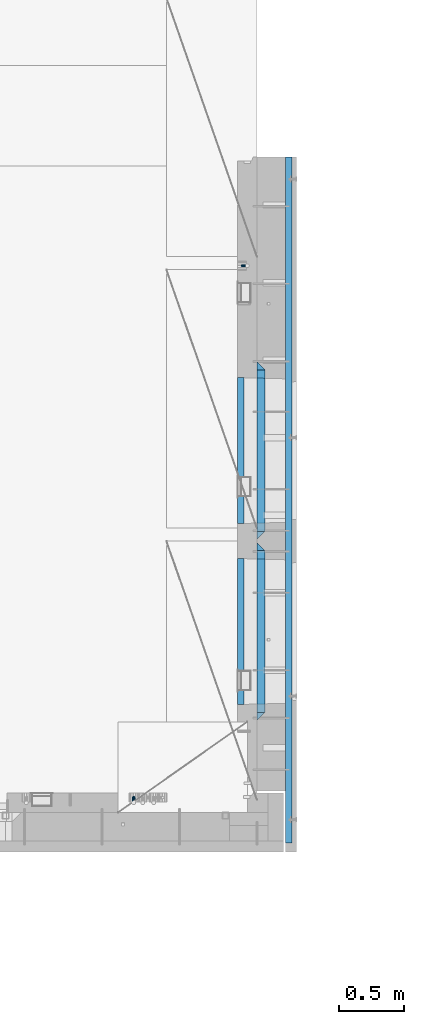
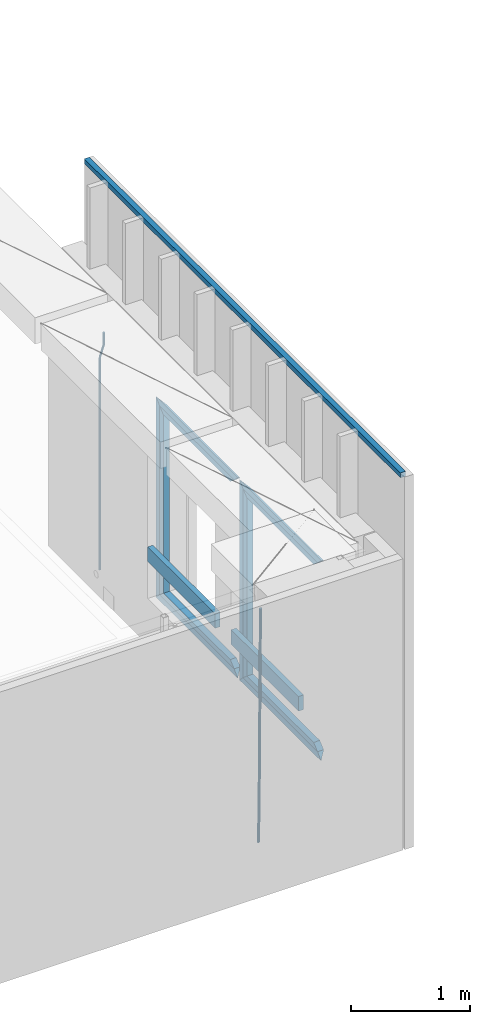
# One storey, part 112 of 309: 17 beams, 2 elements without a shape of their own.
"""IFC2X3 building model written with IfcOpenShell, lengths in millimetres."""

from ifc_helpers import new_model, si_unit, frame, origin_with_axes, place, context, subcontext, project, spatial, faceted_brep, material, type_object, element, aggregate, save


model = new_model("IFC2X3")

# Units and contexts
model_context = context("Model", 3, precision=1e-05, world=origin_with_axes())
body_context = subcontext(model_context, "Body", "Model", "MODEL_VIEW")
ifc_project = project(units=[si_unit("LENGTHUNIT", "METRE", prefix="MILLI"), si_unit("AREAUNIT", "SQUARE_METRE"), si_unit("VOLUMEUNIT", "CUBIC_METRE"), si_unit("MASSUNIT", "GRAM", prefix="KILO"), si_unit("TIMEUNIT", "SECOND"), si_unit("PLANEANGLEUNIT", "RADIAN"), si_unit("SOLIDANGLEUNIT", "STERADIAN"), si_unit("THERMODYNAMICTEMPERATUREUNIT", "DEGREE_CELSIUS"), si_unit("LUMINOUSINTENSITYUNIT", "LUMEN")], contexts=[model_context])

# Site, building, storey
site_placement = place(None, origin_with_axes())
site = spatial("IfcSite", under=ifc_project, at=site_placement, CompositionType="ELEMENT")
building_placement = place(site_placement, origin_with_axes())
building = spatial("IfcBuilding", under=site, at=building_placement, CompositionType="ELEMENT")
storey_placement = place(building_placement, origin_with_axes())
storey = spatial("IfcBuildingStorey", under=building, at=storey_placement, Name="7", CompositionType="ELEMENT", Elevation=0.0)

# Assembly, beam
assembly_1_placement = place(storey_placement, origin_with_axes())
assembly_1 = element("IfcElementAssembly", 1, at=assembly_1_placement, inside=storey, AssemblyPlace="NOTDEFINED", PredefinedType="REINFORCEMENT_UNIT")
ifc_material_1 = material()
beam_type_1 = type_object("IfcBeamType", Name="D20", PredefinedType="NOTDEFINED")
beam_1_placement = place(assembly_1_placement, frame((34985.0, 12080.0002860939, 102407.5), z_axis=(-0.999999913638316, 0.000415599999849952, 0.0), x_axis=(0.0, 0.0, -1.0)))
beam_1 = element("IfcBeam", 2, at=beam_1_placement, type_object=beam_type_1, material=ifc_material_1, Name="JM20", ObjectType="D20", context=body_context, shape_type="Brep", body=[
    faceted_brep([(0.0, -10.0, 0.0), (-4.19531716033816e-08, -7.07106781186667, -7.07106781187031), (113.248091332178, -7.0710684840451, -7.0710678117357), (113.248091314759, -10.0000006713562, -2.51020537689328e-10), (0.0, 0.0, -10.0), (113.248091374131, -6.72178430249915e-07, -9.99999999986903), (4.196772351861e-08, 7.07106781186303, -7.07106781186667), (113.248091416113, 7.07106713968824, -7.07106781173934), (0.0, 10.0, 0.0), (113.248091433488, 9.99999932782521, 1.30967237055302e-10), (4.196772351861e-08, 7.07106781185939, 7.07106781185939), (113.248091416113, 7.0710671396846, 7.071067811994), (0.0, 0.0, 10.0), (113.248091374131, -6.72174792271107e-07, 10.0000000001273), (-4.19531716033816e-08, -7.07106781187031, 7.07106781185939), (113.248091332178, -7.0710684840451, 7.071067811994), (130.699843527167, -7.06993249763036, -4.33745683788584), (128.538066582521, -9.99900540317321, 2.39499413731755), (131.594536475241, 0.00119355250353692, -7.12624594330919), (130.698046432328, 7.07220300913468, -4.33773834422391), (128.535525107087, 10.0009944322555, 2.39459602660281), (126.373748162892, 7.07192152754578, 9.1270470011732), (125.479055214906, 0.000795477419160306, 11.9158361066184), (126.37554525779, -7.07021397921199, 9.12732850753673), (240.336258550378, -7.05529970173666, 30.8729495437874), (238.174481606227, -9.98437260450009, 37.6054005176375), (241.230951498423, 0.0158263482953771, 28.0841604381058), (240.334461455612, 7.0868358050102, 30.8726680369582), (238.171940130502, 10.0156272283348, 37.6050024077231), (236.010163186409, 7.08655432384694, 44.3374533824244), (235.115470238379, 0.0154282738185429, 47.1262424881097), (236.011960281176, -7.05558118289991, 44.3377348892536), (253.461915329972, -7.05444528127919, 32.9289287376414), (253.46191532613, -9.98337746617108, 39.9999965521893), (253.461915339081, 0.0166225284556276, 29.9999965443676), (253.461915348205, 7.08769034247234, 32.9289287273205), (253.461915352003, 10.0166225357716, 39.9999965370152), (253.461915348293, 7.08769035281148, 47.0710643509774), (253.461915339183, 0.0166225430875784, 49.999996544273), (253.46191533003, -7.05444527093641, 47.0710643613093), (2417.50000002384, -7.0544364694706, 32.9289287374122), (2417.5000000337, -9.98336865393321, 39.9999965507959), (2417.49999999997, 0.0166313408753922, 29.9999965456082), (2417.49999997609, 7.08769915426274, 32.9289287300708), (2417.4999999662, 10.0166313460668, 39.9999965404204), (2417.49999997608, 7.08769916160054, 47.0710643538114), (2417.49999999994, 0.0166313512581837, 49.9999965456154), (2417.50000002382, -7.05443646212916, 47.0710643611455)], [[[0, 1, 2, 3]], [[1, 4, 5, 2]], [[4, 6, 7, 5]], [[6, 8, 9, 7]], [[8, 10, 11, 9]], [[10, 12, 13, 11]], [[12, 14, 15, 13]], [[14, 0, 3, 15]], [[14, 12, 10, 8, 6, 4, 1, 0]], [[3, 2, 16, 17]], [[2, 5, 18, 16]], [[5, 7, 19, 18]], [[7, 9, 20, 19]], [[9, 11, 21, 20]], [[11, 13, 22, 21]], [[13, 15, 23, 22]], [[15, 3, 17, 23]], [[17, 16, 24, 25]], [[16, 18, 26, 24]], [[18, 19, 27, 26]], [[19, 20, 28, 27]], [[20, 21, 29, 28]], [[21, 22, 30, 29]], [[22, 23, 31, 30]], [[23, 17, 25, 31]], [[25, 24, 32, 33]], [[24, 26, 34, 32]], [[26, 27, 35, 34]], [[27, 28, 36, 35]], [[28, 29, 37, 36]], [[29, 30, 38, 37]], [[30, 31, 39, 38]], [[31, 25, 33, 39]], [[33, 32, 40, 41]], [[32, 34, 42, 40]], [[34, 35, 43, 42]], [[35, 36, 44, 43]], [[36, 37, 45, 44]], [[37, 38, 46, 45]], [[38, 39, 47, 46]], [[39, 33, 41, 47]], [[42, 43, 44, 45, 46, 47, 41, 40]]]),
])

assembly_2_placement = place(storey_placement, origin_with_axes())
assembly_2 = element("IfcElementAssembly", 3, at=assembly_2_placement, inside=storey, AssemblyPlace="NOTDEFINED", PredefinedType="REINFORCEMENT_UNIT")
beam_type_2 = type_object("IfcBeamType", Name="D25", PredefinedType="NOTDEFINED")
beam_2_placement = place(assembly_2_placement, frame((34104.9999999961, 7965.00000227913, 99990.0), z_axis=(0.00020576299992186, -0.999642804629538, -0.0267249099901004), x_axis=(-4.30000201928125e-08, -0.0267249099948059, 0.999642825806181)))
beam_2 = element("IfcBeam", 4, at=beam_2_placement, type_object=beam_type_2, material=ifc_material_1, Name="JM25", ObjectType="D25", context=body_context, shape_type="Brep", body=[
    faceted_brep([(-7.41420080885291e-08, -12.5, -3.63797880709171e-12), (-6.42030499875546e-08, -10.8253175473074, -6.25000000000364), (60.4103898235917, -10.8253175318459, -6.2499999938409), (60.4103898269532, -12.4999999845422, 6.16273609921336e-09), (-3.70782800018787e-08, -6.25000000000364, -10.8253175473074), (60.4103898202884, -6.24999998454587, -10.8253175411446), (-1.45519152283669e-11, -3.63797880709171e-12, -12.5), (60.4103898179019, 1.54577719513327e-08, -12.4999999938373), (3.70637280866504e-08, 6.25, -10.8253175473074), (60.410389817087, 6.25000001545777, -10.825317541141), (6.42030499875546e-08, 10.8253175473001, -6.25000000000364), (60.410389818062, 10.8253175627578, -6.24999999383726), (7.41420080885291e-08, 12.4999999999927, 0.0), (60.4103898205503, 12.5000000154541, 6.16273609921336e-09), (6.42176019027829e-08, 10.8253175473001, 6.24999999999636), (60.4103898238973, 10.8253175627651, 6.2500000061591), (3.70928319171071e-08, 6.24999999999636, 10.8253175473037), (60.4103898272151, 6.25000001546141, 10.8253175534664), (1.45519152283669e-11, -3.63797880709171e-12, 12.4999999999964), (60.4103898296162, 1.54541339725256e-08, 12.5000000061591), (-3.7049176171422e-08, -6.25000000000364, 10.8253175473001), (60.4103898304165, -6.24999998454587, 10.8253175534701), (-6.41884980723262e-08, -10.8253175473074, 6.25), (60.4103898294561, -10.8253175318459, 6.25000000616637), (61.0324985728803, -10.8253175316895, -6.24999999377542), (60.991802792938, -12.4999999843931, 6.22458173893392e-09), (61.0622854283865, -6.24999998437852, -10.8253175410755), (61.0731819955545, 1.5628756955266e-08, -12.4999999937718), (61.0622685480339, 6.25000001562512, -10.8253175410791), (61.032469335245, 10.8253175629216, -6.24999999377178), (60.9917690322181, 12.5000000156033, 6.22458173893392e-09), (60.9510732522613, 10.8253175629034, 6.25000000621731), (60.9212863967696, 6.25000001558874, 10.8253175535247), (60.9103898296162, 1.55814632307738e-08, 12.5000000062137), (60.9213032771368, -6.24999998441126, 10.8253175535174), (60.9511024898966, -10.8253175317113, 6.25000000621731), (61.6545545670233, -10.8253158516927, -6.24189838219536), (61.573166454793, -12.499998414296, 0.00757164385504439), (61.7141257553885, -6.24999822394238, -10.8168280205282), (61.7359179680789, 1.80548886419274e-06, -12.491368569139), (61.7140919992817, 6.25000177601396, -10.8168282403167), (61.6544960997562, 10.8253192428383, -6.2418987628771), (61.5730989426083, 12.5000015856094, 0.0075712042817031), (61.4917108303925, 10.8253190230062, 6.25704123032847), (61.4321396420273, 6.25000139525582, 10.8319708686649), (61.4103474293224, 1.36582457344048e-06, 12.5065114172721), (61.4321733981196, -6.24999860470052, 10.8319710884571), (61.4917692976451, -10.8253160715249, 6.25704161101385), (176.524302641745, -10.8250056210964, -4.74584321979273), (176.442914529529, -12.4996881836996, 1.50362680625403), (176.583873830095, -6.24968799334965, -9.3207728581292), (176.605666042786, 0.000312036081595579, -10.9953134067364), (176.583840074018, 6.25031200660669, -9.32077307791769), (176.524244174492, 10.8256294734347, -4.74584360047811), (176.44284701733, 12.5003118162058, 1.50362636668069), (176.361458905099, 10.8256292535989, 7.75309639272746), (176.301887716749, 6.25031162585219, 12.3280260310676), (176.280095504058, 0.000311596420942806, 14.0025665796711), (176.301921472827, -6.24968837410415, 12.3280262508561), (176.361517372367, -10.8250058409321, 7.75309677341284), (177.085397012124, -10.8250041057399, -4.73853556792164), (176.983633547483, -12.4996867233749, 1.51066909103247), (177.159881729676, -6.24968643771717, -9.31327097355097), (177.187129580227, 0.000313606451527448, -10.987740468332), (177.159839524218, 6.25031356221734, -9.31327130338468), (177.085323910098, 10.8256309887511, -4.73853613920801), (176.983549136537, 12.5003132764905, 1.51066843136869), (176.881785671867, 10.8256306588555, 7.7598730903228), (176.80730095433, 6.25031299082912, 12.3346084959521), (176.780053103794, 0.000312946667690994, 14.0090779907332), (176.807343159802, -6.2496870091054, 12.3346088257895), (176.881858773908, -10.8250044356355, 7.7598736616128), (177.646431799818, -10.8250018318176, -4.72756919822132), (177.524295146417, -12.4996845320202, 1.52123723245313), (177.735828462886, -6.24968410334986, -9.30201312475765), (177.768531371941, 0.00031596292683389, -10.9763759912421), (177.735777808921, 6.25031589654827, -9.30201361973741), (177.646344064575, 10.8256332626152, -4.72757005553649), (177.524193838486, 12.5003154677688, 1.52123624250817), (177.402057185071, 10.8256327675663, 7.77004267317898), (177.312660521988, 6.2503150390985, 12.3444865997226), (177.279957612933, 0.00031497282179771, 14.0188494661961), (177.312711175953, -6.24968496079964, 12.3444870946951), (177.402144920314, -10.8250023268702, 7.77004353049415), (299.377443161706, -10.8245084454466, -2.34813158632096), (299.255306508276, -12.4991911456491, 3.90067484435349), (299.466839824803, -6.24919071697514, -6.92257551286093), (299.499542733873, 0.0008093492979242, -8.59693837933446), (299.466789170867, 6.250809282923, -6.92257600783341), (299.377355426492, 10.8261266489935, -2.34813244364341), (299.255205200388, 12.5008088541435, 3.90067385440125), (299.133068546944, 10.826126153941, 10.1494802850757), (299.043671883861, 6.25080842546959, 14.7239242116229), (299.010968974762, 0.000808359200163977, 16.3982870780892), (299.043722537797, -6.24919157442127, 14.7239247065918), (299.133156282158, -10.8245089404954, 10.1494811423981), (299.98561436501, -10.8245059804758, -2.33624385599614), (299.97179243555, -12.4991882411778, 3.91467976726199), (299.995742293278, -6.24918857328521, -6.91223722345239), (299.999447243041, 0.000811375455668895, -8.58716690387519), (299.995736475976, 6.25081142679483, -6.91223684201032), (299.985604289133, 10.8261291142808, -2.33624319533556), (299.971750386685, 12.5008117588586, 3.91467993563856), (299.957928457196, 10.8261294971744, 10.1656035610831), (299.947800528913, 6.25081208998381, 14.7415969285394), (299.944095579151, 0.00081214124293183, 16.4165266089549), (299.947806346216, -6.24918791008895, 14.7415965471009), (299.957938533058, -10.8245055975785, 10.1656029004225), (300.593832239858, -10.8245078794353, -2.34543881707941), (300.688302931099, -12.4991904788549, 3.90384712594823), (300.524685350189, -6.24919022474205, -6.92023371784308), (300.499390115292, 0.000809814544481924, -8.59472497713432), (300.524724372954, 6.25080977519247, -6.92023401429469), (300.593899829313, 10.8261272150703, -2.34543933054374), (300.688380976673, 12.5008095210287, 3.90384653304136), (300.782851667915, 10.8261269216127, 10.1531324760799), (300.851998557599, 6.25080926691589, 14.7279273768363), (300.877293792495, 0.000809227632998955, 16.4024186361276), (300.851959534804, -6.24919073302226, 14.7279276732806), (300.782784078474, -10.8245081728965, 10.153132989537), (2293.32930409742, -10.8307295605009, -32.4713622331001), (2293.42377478865, -12.5054121599169, -26.2220762900724), (2293.26015720774, -6.2554119058077, -37.0461571338565), (2293.23486197284, -0.00541186651753378, -38.7206483931477), (2293.26019623051, 6.24458809413409, -37.0461574303008), (2293.32937168686, 10.8199055340046, -32.4713627465644), (2293.42385283421, 12.4945878399631, -26.2220768829684), (2293.51832352545, 10.8199052405434, -19.972790939948), (2293.58747041514, 6.24458758585388, -15.3979960391844), (2293.61276565003, -0.00541245343265473, -13.7235047798931), (2293.58743139236, -6.25541241408428, -15.3979957427327), (2293.51825593603, -10.8307298539585, -19.9727904264691), (2294.0420846676, -10.8307317859326, -32.4821379598216), (2294.03681932652, -12.5054140739521, -26.2313442200393), (2294.06778164886, -6.2554144273563, -37.0583666982457), (2294.10702478497, -0.00541458957013674, -38.7338336404937), (2294.14929890928, 6.24458531819619, -37.0595987724118), (2294.18327670435, 10.8199028679592, -32.4842719748667), (2294.1998538474, 12.4945854171456, -26.2338083683717), (2294.19458850632, 10.819903129126, -19.9830146285858), (2294.16889152506, 6.24458577054975, -15.4067858901581), (2294.12964838895, -0.0054140672327776, -13.7313189479173), (2294.08737426462, -6.2554139749991, -15.4055538159919), (2294.05339646956, -10.8307315247621, -19.9808806135297), (2294.75482297382, -10.84002603931, -32.4726521173216), (2294.64982751427, -12.513407826169, -26.2231856868602), (2294.87535820232, -6.26594539088183, -37.0476186524102), (2294.97913588268, -0.0167870967634371, -38.7222267036377), (2295.0383488692, 6.23299192477134, -37.0477663960555), (2295.03713108998, 10.8087684320271, -32.4729080168181), (2294.97580884799, 12.4844668051373, -26.2234811741473), (2294.87081338844, 10.8110850182784, -19.9740147436787), (2294.7502781599, 6.23700436985018, -15.3990482086047), (2294.64650047956, -0.0121539242718427, -13.7244401573698), (2294.58728749304, -6.26193294580662, -15.3989004649666), (2294.58850527227, -10.8377094530588, -19.9737588441894), (2316.44667268227, -11.1228921988077, -32.1839550346631), (2316.34167722271, -12.7962739856739, -25.9344886042054), (2316.56720791078, -6.54881155039038, -36.7589215697517), (2316.67098559113, -0.299653256264719, -38.4335296209792), (2316.73019857766, 5.95012576527006, -36.759069313397), (2316.72898079845, 10.5259022725259, -32.1842109341669), (2316.66765855643, 12.2016006456361, -25.9347840914961), (2316.56266309689, 10.5282188587698, -19.6853176610275), (2316.44212786836, 5.95413821035254, -15.1103511259389), (2316.33835018802, -0.295020083769487, -13.4357430747186), (2316.27913720149, -6.54479910530426, -15.1102033823008), (2316.28035498071, -11.1205756125637, -19.685061761531), (2317.13234804722, -11.1318335458927, -32.1748293731798), (2317.04181141085, -12.8054038787741, -25.9251705100723), (2317.2154741603, -6.5572650749491, -36.7502937866229), (2317.26891617525, -0.307450393454928, -38.4255717558117), (2317.27835434731, 5.94297770185585, -36.7517739018112), (2317.24125972588, 10.5192220504723, -32.1773930078925), (2317.16757178486, 12.1950816748285, -25.9281307404563), (2317.0770351485, 10.5215113419545, -19.6784718773561), (2316.99390903539, 5.94694287101083, -15.1030074639057), (2316.94046702047, -0.302871810494253, -13.4277294947169), (2316.9310288484, -6.55329990579412, -15.1015273487101), (2316.96812346982, -11.1295442544142, -19.6759082426288), (2317.81808136747, -11.1298054502913, -32.1659056455355), (2317.74200467508, -12.803315894289, -25.9160547315114), (2317.86379538118, -6.55536082026447, -36.7418676070083), (2317.8668976831, -0.305700748642266, -38.417815303761), (2317.82655701396, 5.94458339541234, -36.7446799039099), (2317.75358262347, 10.5207330230332, -32.1707766866384), (2317.66752794063, 12.1965725370646, -25.9216793252963), (2317.59145124823, 10.5230620930706, -19.6718284112721), (2317.54573723453, 5.94861746304377, -15.0958664497994), (2317.54263493262, -0.301042608574789, -13.4199187530394), (2317.58297560175, -6.55132675263303, -15.0930541529051), (2317.65594999224, -11.1274763802539, -19.6669573701693), (2417.81884292323, -10.831603083323, -30.8687911350135), (2417.74276623082, -12.505113527317, -24.618940220982), (2417.86455693691, -6.25715845329614, -35.4447530964935), (2417.86765923884, -0.00749838167394046, -37.1207007932499), (2417.82731856969, 6.24278576237703, -35.4475653933878), (2417.75434417921, 10.8189353900088, -30.8736621761236), (2417.66828949639, 12.494774904033, -24.6245648147851), (2417.59221280397, 10.8212644600353, -18.3747139007501), (2417.54649879028, 6.2468198300121, -13.79875193927), (2417.54339648837, -0.00284024161010166, -12.1228042425173), (2417.5837371575, -6.25312438566107, -13.795939642383), (2417.65671154798, -10.8292740132893, -18.3698428596399)], [[[0, 1, 2, 3]], [[1, 4, 5, 2]], [[4, 6, 7, 5]], [[6, 8, 9, 7]], [[8, 10, 11, 9]], [[10, 12, 13, 11]], [[12, 14, 15, 13]], [[14, 16, 17, 15]], [[16, 18, 19, 17]], [[18, 20, 21, 19]], [[20, 22, 23, 21]], [[22, 0, 3, 23]], [[22, 20, 18, 16, 14, 12, 10, 8, 6, 4, 1, 0]], [[3, 2, 24, 25]], [[2, 5, 26, 24]], [[5, 7, 27, 26]], [[7, 9, 28, 27]], [[9, 11, 29, 28]], [[11, 13, 30, 29]], [[13, 15, 31, 30]], [[15, 17, 32, 31]], [[17, 19, 33, 32]], [[19, 21, 34, 33]], [[21, 23, 35, 34]], [[23, 3, 25, 35]], [[25, 24, 36, 37]], [[24, 26, 38, 36]], [[26, 27, 39, 38]], [[27, 28, 40, 39]], [[28, 29, 41, 40]], [[29, 30, 42, 41]], [[30, 31, 43, 42]], [[31, 32, 44, 43]], [[32, 33, 45, 44]], [[33, 34, 46, 45]], [[34, 35, 47, 46]], [[35, 25, 37, 47]], [[37, 36, 48, 49]], [[36, 38, 50, 48]], [[38, 39, 51, 50]], [[39, 40, 52, 51]], [[40, 41, 53, 52]], [[41, 42, 54, 53]], [[42, 43, 55, 54]], [[43, 44, 56, 55]], [[44, 45, 57, 56]], [[45, 46, 58, 57]], [[46, 47, 59, 58]], [[47, 37, 49, 59]], [[49, 48, 60, 61]], [[48, 50, 62, 60]], [[50, 51, 63, 62]], [[51, 52, 64, 63]], [[52, 53, 65, 64]], [[53, 54, 66, 65]], [[54, 55, 67, 66]], [[55, 56, 68, 67]], [[56, 57, 69, 68]], [[57, 58, 70, 69]], [[58, 59, 71, 70]], [[59, 49, 61, 71]], [[61, 60, 72, 73]], [[60, 62, 74, 72]], [[62, 63, 75, 74]], [[63, 64, 76, 75]], [[64, 65, 77, 76]], [[65, 66, 78, 77]], [[66, 67, 79, 78]], [[67, 68, 80, 79]], [[68, 69, 81, 80]], [[69, 70, 82, 81]], [[70, 71, 83, 82]], [[71, 61, 73, 83]], [[73, 72, 84, 85]], [[72, 74, 86, 84]], [[74, 75, 87, 86]], [[75, 76, 88, 87]], [[76, 77, 89, 88]], [[77, 78, 90, 89]], [[78, 79, 91, 90]], [[79, 80, 92, 91]], [[80, 81, 93, 92]], [[81, 82, 94, 93]], [[82, 83, 95, 94]], [[83, 73, 85, 95]], [[85, 84, 96, 97]], [[84, 86, 98, 96]], [[86, 87, 99, 98]], [[87, 88, 100, 99]], [[88, 89, 101, 100]], [[89, 90, 102, 101]], [[90, 91, 103, 102]], [[91, 92, 104, 103]], [[92, 93, 105, 104]], [[93, 94, 106, 105]], [[94, 95, 107, 106]], [[95, 85, 97, 107]], [[97, 96, 108, 109]], [[96, 98, 110, 108]], [[98, 99, 111, 110]], [[99, 100, 112, 111]], [[100, 101, 113, 112]], [[101, 102, 114, 113]], [[102, 103, 115, 114]], [[103, 104, 116, 115]], [[104, 105, 117, 116]], [[105, 106, 118, 117]], [[106, 107, 119, 118]], [[107, 97, 109, 119]], [[109, 108, 120, 121]], [[108, 110, 122, 120]], [[110, 111, 123, 122]], [[111, 112, 124, 123]], [[112, 113, 125, 124]], [[113, 114, 126, 125]], [[114, 115, 127, 126]], [[115, 116, 128, 127]], [[116, 117, 129, 128]], [[117, 118, 130, 129]], [[118, 119, 131, 130]], [[119, 109, 121, 131]], [[121, 120, 132, 133]], [[120, 122, 134, 132]], [[122, 123, 135, 134]], [[123, 124, 136, 135]], [[124, 125, 137, 136]], [[125, 126, 138, 137]], [[126, 127, 139, 138]], [[127, 128, 140, 139]], [[128, 129, 141, 140]], [[129, 130, 142, 141]], [[130, 131, 143, 142]], [[131, 121, 133, 143]], [[133, 132, 144, 145]], [[132, 134, 146, 144]], [[134, 135, 147, 146]], [[135, 136, 148, 147]], [[136, 137, 149, 148]], [[137, 138, 150, 149]], [[138, 139, 151, 150]], [[139, 140, 152, 151]], [[140, 141, 153, 152]], [[141, 142, 154, 153]], [[142, 143, 155, 154]], [[143, 133, 145, 155]], [[145, 144, 156, 157]], [[144, 146, 158, 156]], [[146, 147, 159, 158]], [[147, 148, 160, 159]], [[148, 149, 161, 160]], [[149, 150, 162, 161]], [[150, 151, 163, 162]], [[151, 152, 164, 163]], [[152, 153, 165, 164]], [[153, 154, 166, 165]], [[154, 155, 167, 166]], [[155, 145, 157, 167]], [[157, 156, 168, 169]], [[156, 158, 170, 168]], [[158, 159, 171, 170]], [[159, 160, 172, 171]], [[160, 161, 173, 172]], [[161, 162, 174, 173]], [[162, 163, 175, 174]], [[163, 164, 176, 175]], [[164, 165, 177, 176]], [[165, 166, 178, 177]], [[166, 167, 179, 178]], [[167, 157, 169, 179]], [[169, 168, 180, 181]], [[168, 170, 182, 180]], [[170, 171, 183, 182]], [[171, 172, 184, 183]], [[172, 173, 185, 184]], [[173, 174, 186, 185]], [[174, 175, 187, 186]], [[175, 176, 188, 187]], [[176, 177, 189, 188]], [[177, 178, 190, 189]], [[178, 179, 191, 190]], [[179, 169, 181, 191]], [[181, 180, 192, 193]], [[180, 182, 194, 192]], [[182, 183, 195, 194]], [[183, 184, 196, 195]], [[184, 185, 197, 196]], [[185, 186, 198, 197]], [[186, 187, 199, 198]], [[187, 188, 200, 199]], [[188, 189, 201, 200]], [[189, 190, 202, 201]], [[190, 191, 203, 202]], [[191, 181, 193, 203]], [[194, 195, 196, 197, 198, 199, 200, 201, 202, 203, 193, 192]]]),
])
aggregate(assembly_2, [beam_2])

# Beam
ifc_material_2 = material(Name="TIMBER/T24")
beam_type_3 = type_object("IfcBeamType", Name="PK50X50", PredefinedType="NOTDEFINED")
beam_3_placement = place(assembly_1_placement, frame((35305.0, 12920.2502861023, 103545.0), z_axis=(0.0, 0.0, 1.0), x_axis=(0.0, -1.0, 0.0)))
beam_3 = element("IfcBeam", 5, at=beam_3_placement, type_object=beam_type_3, material=ifc_material_2, ObjectType="PK50X50", context=body_context, shape_type="Brep", body=[
    faceted_brep([(0.0, 25.0, 25.0), (0.0, -25.0, 25.0), (5305.25028610229, -25.0, 25.0), (5305.25028610229, 25.0, 25.0), (0.0, -25.0, -25.0), (5305.25028610229, -25.0, -25.0), (0.0, 25.0, -25.0), (5305.25028610229, 25.0, -25.0)], [[[0, 1, 2, 3]], [[1, 4, 5, 2]], [[4, 6, 7, 5]], [[6, 0, 3, 7]], [[5, 7, 3, 2]], [[4, 1, 0, 6]]]),
])

beam_type_4 = type_object("IfcBeamType", PredefinedType="NOTDEFINED")
beam_4_placement = place(assembly_1_placement, frame((34935.0002758707, 8685.00118845241, 100685.0), z_axis=(0.0, 0.0, 1.0), x_axis=(0.0, 1.0, 0.0)))
beam_4 = element("IfcBeam", 6, at=beam_4_placement, type_object=beam_type_4, material=ifc_material_2, context=body_context, shape_type="Brep", body=[
    faceted_brep([(-3.63797880709171e-12, 24.9999999999964, -75.0), (-3.63797880709171e-12, 24.9999999999964, 75.0), (1130.0, 25.0, 75.0), (1130.0, 25.0, -75.0), (0.0, -25.0000000000073, 75.0), (1130.0, -25.0, 75.0), (0.0, -25.0000000000073, -75.0), (1130.0, -25.0, -75.0)], [[[0, 1, 2, 3]], [[1, 4, 5, 2]], [[4, 6, 7, 5]], [[6, 0, 3, 7]], [[5, 7, 3, 2]], [[6, 4, 1, 0]]]),
])

beam_5_placement = place(assembly_1_placement, frame((34935.0002758707, 10085.0011884524, 100685.0), z_axis=(0.0, 0.0, 1.0), x_axis=(0.0, 1.0, 0.0)))
beam_5 = element("IfcBeam", 7, at=beam_5_placement, type_object=beam_type_4, material=ifc_material_2, context=body_context, shape_type="Brep", body=[
    faceted_brep([(-3.63797880709171e-12, 24.9999999999964, -75.0), (-3.63797880709171e-12, 24.9999999999964, 75.0), (1130.0, 25.0, 75.0), (1130.0, 25.0, -75.0), (0.0, -25.0000000000073, 75.0), (1130.0, -25.0, 75.0), (0.0, -25.0000000000073, -75.0), (1130.0, -25.0, -75.0)], [[[0, 1, 2, 3]], [[1, 4, 5, 2]], [[4, 6, 7, 5]], [[6, 0, 3, 7]], [[5, 7, 3, 2]], [[6, 4, 1, 0]]]),
])

ifc_material_3 = material(Name="CONCRETE/C25/30")
beam_type_5 = type_object("IfcBeamType", PredefinedType="NOTDEFINED")
beam_6_placement = place(assembly_1_placement, frame((35090.0, 8565.0001381367, 102145.0), z_axis=(0.0, 0.0, -1.0), x_axis=(0.0, 1.0, 0.0)))
beam_6 = element("IfcBeam", 8, at=beam_6_placement, type_object=beam_type_5, material=ifc_material_3, Name="SK", context=body_context, shape_type="Brep", body=[
    faceted_brep([(60.0000000000073, 30.0, 30.0), (0.0, -30.0, -30.0), (60.0000000000073, -30.0, 30.0), (1309.99990463256, 30.0, 30.0), (1369.99990463257, -30.0, -30.0), (1309.99990463256, -30.0, 30.0)], [[[0, 1, 2]], [[1, 0, 3, 4]], [[2, 1, 4, 5]], [[0, 2, 5, 3]], [[4, 3, 5]]]),
])

beam_7_placement = place(assembly_1_placement, frame((35090.0, 8625.0001381367, 102085.0), z_axis=(0.0, 0.0, -1.0), x_axis=(0.0, 1.0, 0.0)))
beam_7 = element("IfcBeam", 9, at=beam_7_placement, type_object=beam_type_5, material=ifc_material_3, Name="SK", context=body_context, shape_type="Brep", body=[
    faceted_brep([(65.6755803082433, 30.0, 25.6756756756804), (64.0539586866216, -30.0, 24.0540540540533), (1185.94585057852, -30.0, 24.0540540540533), (1184.32422895689, 30.0, 25.6756756756804), (65.6755803082433, 30.0, 26.2933545375708), (64.0539586866216, -30.0, 24.9033931479062), (0.0, -30.0, -30.0), (0.0, 30.0, -30.0), (1249.99990463257, 30.0, -30.0), (1249.99990463257, -30.0, -30.0), (1185.94585057852, -30.0, 24.9034748914273), (1184.32422895689, 30.0, 26.293436281092)], [[[0, 1, 2, 3]], [[1, 0, 4, 5]], [[6, 5, 4, 7]], [[6, 7, 8, 9]], [[2, 1, 5, 6, 9, 10]], [[3, 2, 10, 11]], [[7, 4, 0, 3, 11, 8]], [[10, 9, 8, 11]]]),
])

beam_8_placement = place(assembly_1_placement, frame((35090.0, 9905.00004276927, 102175.0), z_axis=(0.0, -1.0, 0.0), x_axis=(0.0, 0.0, -1.0)))
beam_8 = element("IfcBeam", 10, at=beam_8_placement, type_object=beam_type_5, material=ifc_material_3, Name="SK", context=body_context, shape_type="Brep", body=[
    faceted_brep([(60.0000000000073, 30.0, 30.0), (0.0, -30.0, -30.0), (60.0000000000073, -30.0, 30.0), (1995.0, 30.0, 30.0), (2055.0, -30.0, -30.0), (1995.0, -30.0, 30.0)], [[[0, 1, 2]], [[3, 4, 1, 0]], [[4, 5, 2, 1]], [[5, 3, 0, 2]], [[5, 4, 3]]]),
])

beam_9_placement = place(assembly_1_placement, frame((35090.0, 9875.00004276927, 100210.0), z_axis=(0.0, 0.0, 1.0), x_axis=(0.0, -1.0, 0.0)))
beam_9 = element("IfcBeam", 11, at=beam_9_placement, type_object=beam_type_5, material=ifc_material_3, Name="SK", context=body_context, shape_type="Brep", body=[
    faceted_brep([(1185.94594588314, -29.9999988381387, 24.0540541168593), (1184.32432432432, 29.9999988381387, 25.6756756756804), (65.6756756756768, 30.0, 25.6756756756804), (64.0540540540533, -30.0, 24.0540540540533), (1185.94594594595, -30.0, 24.9033931479207), (1184.32432432433, 30.0, 26.2933545375854), (1249.99990463257, -30.0, -30.0), (1249.99990463257, 30.0, -30.0), (0.0, 30.0, -30.0), (65.6756756756768, 30.0, 26.293436281092), (64.0540540540533, -30.0, 24.9034748914419), (0.0, -30.0, -30.0)], [[[0, 1, 2, 3]], [[1, 0, 4, 5]], [[6, 7, 5, 4]], [[2, 1, 5, 7, 8, 9]], [[3, 2, 9, 10]], [[6, 4, 0, 3, 10, 11]], [[11, 8, 7, 6]], [[11, 10, 9, 8]]]),
])

beam_10_placement = place(assembly_1_placement, frame((35090.0, 9935.00004276927, 100150.0), z_axis=(0.0, 0.0, 1.0), x_axis=(0.0, -1.0, 0.0)))
beam_10 = element("IfcBeam", 12, at=beam_10_placement, type_object=beam_type_5, material=ifc_material_3, Name="SK", context=body_context, shape_type="Brep", body=[
    faceted_brep([(1369.99990463257, -30.0, -30.0), (1309.99990463256, 30.0, 30.0), (1309.99990463256, -30.0, 30.0), (60.0000000000073, 30.0, 30.0), (60.0000000000073, -30.0, 30.0), (0.0, -30.0, -30.0)], [[[0, 1, 2]], [[3, 4, 2, 1]], [[4, 5, 0, 2]], [[5, 3, 1, 0]], [[3, 5, 4]]]),
])

beam_11_placement = place(assembly_1_placement, frame((35090.0, 9965.00023350414, 102145.0), z_axis=(0.0, 0.0, -1.0), x_axis=(0.0, 1.0, 0.0)))
beam_11 = element("IfcBeam", 13, at=beam_11_placement, type_object=beam_type_5, material=ifc_material_3, Name="SK", context=body_context, shape_type="Brep", body=[
    faceted_brep([(60.0000000000073, 30.0, 30.0), (0.0, -30.0, -30.0), (60.0000000000073, -30.0, 30.0), (1309.99942779541, 30.0, 30.0), (1369.99942779541, -30.0, -30.0), (1309.99942779541, -30.0, 30.0)], [[[0, 1, 2]], [[1, 0, 3, 4]], [[2, 1, 4, 5]], [[0, 2, 5, 3]], [[4, 3, 5]]]),
])

beam_12_placement = place(assembly_1_placement, frame((35090.0, 10025.0002335041, 102085.0), z_axis=(0.0, 0.0, -1.0), x_axis=(0.0, 1.0, 0.0)))
beam_12 = element("IfcBeam", 14, at=beam_12_placement, type_object=beam_type_5, material=ifc_material_3, Name="SK", context=body_context, shape_type="Brep", body=[
    faceted_brep([(65.6751034710851, 30.0, 25.6756756756804), (64.0534818494634, -30.0, 24.0540540540533), (1185.94537374136, -30.0, 24.0540540540533), (1184.32375211974, 30.0, 25.6756756756804), (65.6751034710851, 30.0, 26.2929458199942), (64.0534818494634, -30.0, 24.9029844303586), (0.0, -30.0, -30.0), (0.0, 30.0, -30.0), (1249.99942779541, 30.0, -30.0), (1249.99942779541, -30.0, -30.0), (1185.94537374136, -30.0, 24.9034748914273), (1184.32375211974, 30.0, 26.293436281092)], [[[0, 1, 2, 3]], [[1, 0, 4, 5]], [[6, 5, 4, 7]], [[6, 7, 8, 9]], [[2, 1, 5, 6, 9, 10]], [[3, 2, 10, 11]], [[7, 4, 0, 3, 11, 8]], [[10, 9, 8, 11]]]),
])

beam_13_placement = place(assembly_1_placement, frame((35090.0, 11304.9996612995, 102175.0), z_axis=(0.0, -1.0, 0.0), x_axis=(0.0, 0.0, -1.0)))
beam_13 = element("IfcBeam", 15, at=beam_13_placement, type_object=beam_type_5, material=ifc_material_3, Name="SK", context=body_context, shape_type="Brep", body=[
    faceted_brep([(60.0000000000073, 30.0, 30.0), (0.0, -30.0, -30.0), (60.0000000000073, -30.0, 30.0), (1995.0, 30.0, 30.0), (2055.0, -30.0, -30.0), (1995.0, -30.0, 30.0)], [[[0, 1, 2]], [[3, 4, 1, 0]], [[4, 5, 2, 1]], [[5, 3, 0, 2]], [[5, 4, 3]]]),
])

beam_14_placement = place(assembly_1_placement, frame((35090.0, 11274.9996612995, 100210.0), z_axis=(0.0, 0.0, 1.0), x_axis=(0.0, -1.0, 0.0)))
beam_14 = element("IfcBeam", 16, at=beam_14_placement, type_object=beam_type_5, material=ifc_material_3, Name="SK", context=body_context, shape_type="Brep", body=[
    faceted_brep([(1185.94594588314, -29.9999988381387, 24.0540541168593), (1184.32432432432, 29.9999988381387, 25.6756756756804), (65.6756756756768, 30.0, 25.6756756756804), (64.0540540540533, -30.0, 24.0540540540533), (1185.94594594595, -30.0, 24.9029844303586), (1184.32432432433, 30.0, 26.2929458200088), (1249.99942779541, -30.0, -30.0), (1249.99942779541, 30.0, -30.0), (0.0, 30.0, -30.0), (65.6756756756768, 30.0, 26.293436281092), (64.0540540540533, -30.0, 24.9034748914419), (0.0, -30.0, -30.0)], [[[0, 1, 2, 3]], [[1, 0, 4, 5]], [[6, 7, 5, 4]], [[2, 1, 5, 7, 8, 9]], [[3, 2, 9, 10]], [[6, 4, 0, 3, 10, 11]], [[11, 8, 7, 6]], [[11, 10, 9, 8]]]),
])

beam_15_placement = place(assembly_1_placement, frame((35090.0, 11334.9996612995, 100150.0), z_axis=(0.0, 0.0, 1.0), x_axis=(0.0, -1.0, 0.0)))
beam_15 = element("IfcBeam", 17, at=beam_15_placement, type_object=beam_type_5, material=ifc_material_3, Name="SK", context=body_context, shape_type="Brep", body=[
    faceted_brep([(1369.99942779541, -30.0, -30.0), (1309.99942779541, 30.0, 30.0), (1309.99942779541, -30.0, 30.0), (60.0000000000073, 30.0, 30.0), (60.0000000000073, -30.0, 30.0), (0.0, -30.0, -30.0)], [[[0, 1, 2]], [[3, 4, 2, 1]], [[4, 5, 0, 2]], [[5, 3, 1, 0]], [[3, 5, 4]]]),
])

beam_type_6 = type_object("IfcBeamType", PredefinedType="NOTDEFINED")
beam_16_placement = place(assembly_1_placement, frame((35090.0, 9840.00004276927, 102115.0), z_axis=(0.0, -1.0, 0.0), x_axis=(0.0, 0.0, -1.0)))
beam_16 = element("IfcBeam", 18, at=beam_16_placement, type_object=beam_type_6, material=ifc_material_3, Name="SK", context=body_context, shape_type="Brep", body=[
    faceted_brep([(0.0, -30.0, -35.0), (54.9034748914273, -30.0, 29.0540540540533), (56.2934362811066, 30.0, 30.6756756756768), (0.0, 30.0, -35.0), (1935.0, 30.0, -35.0), (1935.0, -30.0, -35.0), (1880.09652510857, -30.0, 29.0540540540533), (1878.70656371891, 30.0, 30.6756756756749)], [[[0, 1, 2, 3]], [[4, 5, 0, 3]], [[1, 0, 5, 6]], [[2, 1, 6, 7]], [[3, 2, 7, 4]], [[6, 5, 4, 7]]]),
])

beam_17_placement = place(assembly_1_placement, frame((35090.0, 11239.9996612995, 102115.0), z_axis=(0.0, -1.0, 0.0), x_axis=(0.0, 0.0, -1.0)))
beam_17 = element("IfcBeam", 19, at=beam_17_placement, type_object=beam_type_6, material=ifc_material_3, Name="SK", context=body_context, shape_type="Brep", body=[
    faceted_brep([(0.0, -30.0, -35.0), (54.9034748914273, -30.0, 29.0540540540533), (56.2934362811066, 30.0, 30.6756756756768), (0.0, 30.0, -35.0), (1935.0, 30.0, -35.0), (1935.0, -30.0, -35.0), (1880.09652510857, -30.0, 29.0540540540533), (1878.70656371891, 30.0, 30.6756756756749)], [[[0, 1, 2, 3]], [[4, 5, 0, 3]], [[1, 0, 5, 6]], [[2, 1, 6, 7]], [[3, 2, 7, 4]], [[6, 5, 4, 7]]]),
])

aggregate(assembly_1, [beam_1, beam_3, beam_4, beam_5, beam_6, beam_7, beam_8, beam_16, beam_9, beam_10, beam_11, beam_12, beam_13, beam_17, beam_14, beam_15])

save(model, "model.ifc")
